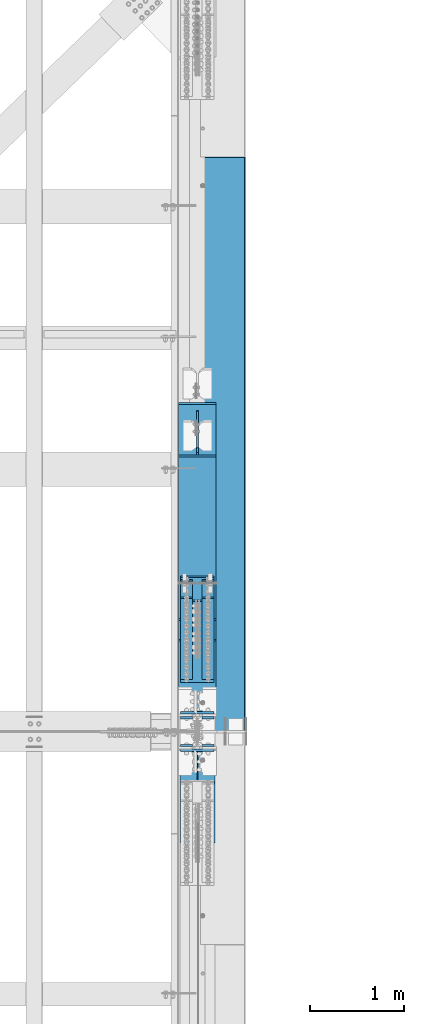
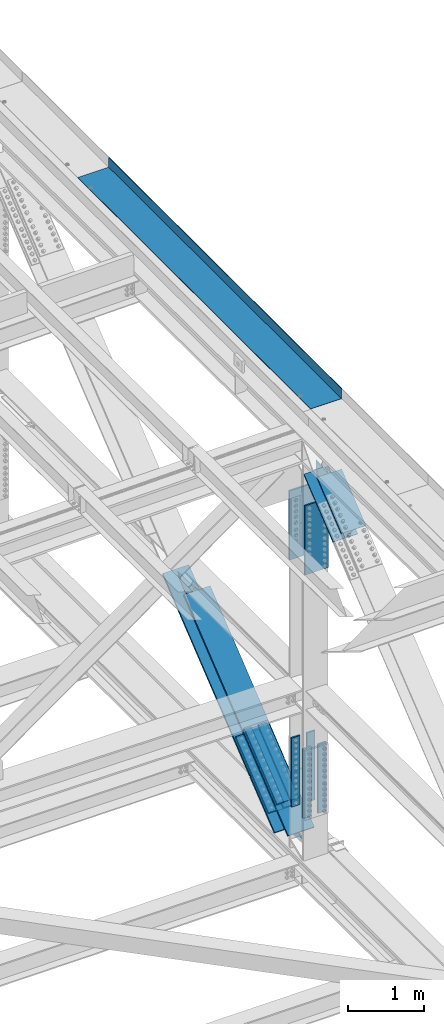
# One storey, part 1981 of 3843: 9 members, 7 beams, 4 elements without a shape of their own.
"""IFC2X3 building model written with IfcOpenShell, lengths in millimetres."""

from ifc_helpers import new_model, si_unit, frame, origin_with_axes, place, context, subcontext, project, spatial, faceted_brep, material, type_object, element, aggregate, save


model = new_model("IFC2X3")

# Units and contexts
model_context = context("Model", 3, precision=1e-05, world=origin_with_axes())
body_context = subcontext(model_context, "Body", "Model", "MODEL_VIEW")
ifc_project = project(units=[si_unit("LENGTHUNIT", "METRE", prefix="MILLI"), si_unit("AREAUNIT", "SQUARE_METRE"), si_unit("VOLUMEUNIT", "CUBIC_METRE"), si_unit("MASSUNIT", "GRAM", prefix="KILO"), si_unit("TIMEUNIT", "SECOND"), si_unit("PLANEANGLEUNIT", "RADIAN"), si_unit("SOLIDANGLEUNIT", "STERADIAN"), si_unit("THERMODYNAMICTEMPERATUREUNIT", "DEGREE_CELSIUS"), si_unit("LUMINOUSINTENSITYUNIT", "LUMEN")], contexts=[model_context])

# Site, building, storey
site_placement = place(None, origin_with_axes())
site = spatial("IfcSite", under=ifc_project, at=site_placement, CompositionType="ELEMENT")
building_placement = place(site_placement, origin_with_axes())
building = spatial("IfcBuilding", under=site, at=building_placement, Name="Undefined", CompositionType="ELEMENT")
storey_placement = place(building_placement, origin_with_axes())
storey = spatial("IfcBuildingStorey", under=building, at=storey_placement, Name="Undefined", CompositionType="ELEMENT", Elevation=0.0)

# Assembly, members
assembly_1_placement = place(storey_placement, origin_with_axes())
assembly_1 = element("IfcElementAssembly", 1, at=assembly_1_placement, inside=storey, Name="BEAM", AssemblyPlace="NOTDEFINED", PredefinedType="RIGID_FRAME")
ifc_material_1 = material(Name="STEEL/A572-50")
member_type_1 = type_object("IfcMemberType", PredefinedType="NOTDEFINED")
member_1_placement = place(assembly_1_placement, frame((85534.5, 77235.996749071, 40636.5082633789), z_axis=(1.0, 0.0, 0.0), x_axis=(0.0, -0.778233356622221, -0.62797519269515)))
member_1 = element("IfcMember", 2, at=member_1_placement, type_object=member_type_1, material=ifc_material_1, Name="PLATE", context=body_context, shape_type="Brep", body=[
    faceted_brep([(-4.36557456851006e-11, 12.7000000000116, -63.5), (-4.36557456851006e-11, 12.7000000000116, 63.5), (1104.90000001677, 12.7000000017251, 63.5), (1104.90000001677, 12.7000000017251, -63.5), (1.45519152283669e-11, -12.700000000008, 63.5), (1104.90000001682, -12.6999999982909, 63.5), (1.45519152283669e-11, -12.700000000008, -63.5), (1104.90000001682, -12.6999999982909, -63.5)], [[[0, 1, 2, 3]], [[1, 4, 5, 2]], [[4, 6, 7, 5]], [[6, 0, 3, 7]], [[5, 7, 3, 2]], [[6, 4, 1, 0]]]),
])
member_2_placement = place(assembly_1_placement, frame((85534.5, 77050.5713740765, 40866.3011174216), z_axis=(1.0, 0.0, 0.0), x_axis=(0.0, -0.778233356622221, -0.62797519269515)))
member_2 = element("IfcMember", 3, at=member_2_placement, type_object=member_type_1, material=ifc_material_1, Name="PLATE", context=body_context, shape_type="Brep", body=[
    faceted_brep([(-4.36557456851006e-11, 12.7000000000116, -63.5), (-4.36557456851006e-11, 12.7000000000116, 63.5), (1104.90000001677, 12.7000000017251, 63.5), (1104.90000001677, 12.7000000017251, -63.5), (1.45519152283669e-11, -12.700000000008, 63.5), (1104.90000001682, -12.6999999982909, 63.5), (1.45519152283669e-11, -12.700000000008, -63.5), (1104.90000001682, -12.6999999982909, -63.5)], [[[0, 1, 2, 3]], [[1, 4, 5, 2]], [[4, 6, 7, 5]], [[6, 0, 3, 7]], [[5, 7, 3, 2]], [[6, 4, 1, 0]]]),
])
member_3_placement = place(assembly_1_placement, frame((85763.1, 77235.9967490711, 40636.5082633788), z_axis=(1.0, 0.0, 0.0), x_axis=(0.0, -0.778233356622221, -0.62797519269515)))
member_3 = element("IfcMember", 4, at=member_3_placement, type_object=member_type_1, material=ifc_material_1, Name="PLATE", context=body_context, shape_type="Brep", body=[
    faceted_brep([(-4.36557456851006e-11, 12.7000000000116, -63.5), (-4.36557456851006e-11, 12.7000000000116, 63.5), (1104.90000001677, 12.7000000017251, 63.5), (1104.90000001677, 12.7000000017251, -63.5), (1.45519152283669e-11, -12.700000000008, 63.5), (1104.90000001682, -12.6999999982909, 63.5), (1.45519152283669e-11, -12.700000000008, -63.5), (1104.90000001682, -12.6999999982909, -63.5)], [[[0, 1, 2, 3]], [[1, 4, 5, 2]], [[4, 6, 7, 5]], [[6, 0, 3, 7]], [[5, 7, 3, 2]], [[6, 4, 1, 0]]]),
])
member_4_placement = place(assembly_1_placement, frame((85763.1, 77050.5713745982, 40866.3011167751), z_axis=(1.0, 0.0, 0.0), x_axis=(0.0, -0.778233356622221, -0.62797519269515)))
member_4 = element("IfcMember", 5, at=member_4_placement, type_object=member_type_1, material=ifc_material_1, Name="PLATE", context=body_context, shape_type="Brep", body=[
    faceted_brep([(-4.36557456851006e-11, 12.7000000000116, -63.5), (-4.36557456851006e-11, 12.7000000000116, 63.5), (1104.90000001677, 12.7000000017251, 63.5), (1104.90000001677, 12.7000000017251, -63.5), (1.45519152283669e-11, -12.700000000008, 63.5), (1104.90000001682, -12.6999999982909, 63.5), (1.45519152283669e-11, -12.700000000008, -63.5), (1104.90000001682, -12.6999999982909, -63.5)], [[[0, 1, 2, 3]], [[1, 4, 5, 2]], [[4, 6, 7, 5]], [[6, 0, 3, 7]], [[5, 7, 3, 2]], [[6, 4, 1, 0]]]),
])
member_type_2 = type_object("IfcMemberType", PredefinedType="NOTDEFINED")
member_5_placement = place(assembly_1_placement, frame((85648.8, 76411.0185856349, 39899.4178813718), z_axis=(1.0, 0.0, 0.0), x_axis=(0.0, 0.778233356622216, 0.627975192695157)))
member_5 = element("IfcMember", 6, at=member_5_placement, type_object=member_type_2, material=ifc_material_1, Name="PLATE", context=body_context, shape_type="Brep", body=[
    faceted_brep([(-1.45519152283669e-11, 12.7000000000025, -177.800000000003), (-1.45519152283669e-11, 12.7000000000025, 177.800000000003), (1104.90000001682, 12.7000000017051, 177.800000000003), (1104.90000001682, 12.7000000017051, -177.800000000003), (4.36557456851006e-11, -12.7000000000171, 177.800000000003), (1104.90000001686, -12.6999999983072, 177.800000000003), (4.36557456851006e-11, -12.7000000000171, -177.800000000003), (1104.90000001686, -12.6999999983072, -177.800000000003)], [[[0, 1, 2, 3]], [[1, 4, 5, 2]], [[4, 6, 7, 5]], [[6, 0, 3, 7]], [[5, 7, 3, 2]], [[6, 4, 1, 0]]]),
])
member_6_placement = place(assembly_1_placement, frame((85648.8, 76155.8094669572, 40215.6919175462), z_axis=(1.0, 0.0, 0.0), x_axis=(0.0, 0.778233356622216, 0.627975192695157)))
member_6 = element("IfcMember", 7, at=member_6_placement, type_object=member_type_2, material=ifc_material_1, Name="PLATE", context=body_context, shape_type="Brep", body=[
    faceted_brep([(-1.45519152283669e-11, 12.7000000000025, -177.800000000003), (-1.45519152283669e-11, 12.7000000000025, 177.800000000003), (1104.90000001682, 12.7000000017051, 177.800000000003), (1104.90000001682, 12.7000000017051, -177.800000000003), (4.36557456851006e-11, -12.7000000000171, 177.800000000003), (1104.90000001686, -12.6999999983072, 177.800000000003), (4.36557456851006e-11, -12.7000000000171, -177.800000000003), (1104.90000001686, -12.6999999983072, -177.800000000003)], [[[0, 1, 2, 3]], [[1, 4, 5, 2]], [[4, 6, 7, 5]], [[6, 0, 3, 7]], [[5, 7, 3, 2]], [[6, 4, 1, 0]]]),
])

# Assembly, member
assembly_2_placement = place(storey_placement, origin_with_axes())
assembly_2 = element("IfcElementAssembly", 8, at=assembly_2_placement, inside=storey, Name="BEAM", AssemblyPlace="NOTDEFINED", PredefinedType="RIGID_FRAME")
ifc_material_2 = material(Name="STEEL/A992")
member_type_3 = type_object("IfcMemberType", Name="W14X99", PredefinedType="NOTDEFINED")
member_7_placement = place(assembly_2_placement, frame((85648.8, 74556.0890731402, 45434.5200894619), z_axis=(0.0, -0.628634438193607, 0.777700934239511), x_axis=(0.0, 0.777700934239509, 0.628634438193609)))
member_7 = element("IfcMember", 9, at=member_7_placement, type_object=member_type_3, material=ifc_material_2, Name="BEAM", ObjectType="W14X99", context=body_context, shape_type="Brep", body=[
    faceted_brep([(863.036991471847, 6.35000000000582, 131.548571949694), (883.164308317369, -6.35000000000582, 131.535296008129), (1099.85576210526, -6.35000000000582, -44.9452300874618), (1082.0284716633, 6.35000000000582, -46.8051700140422), (799.409599719962, 6.35000000000582, 131.590540461475), (799.409599719962, -6.35000000000582, 131.590540461475), (794.370695951802, 6.35000000000582, 133.036446999322), (794.370695951802, -6.35000000000582, 133.036446999322), (790.86000180518, 6.35000000000582, 136.929546472711), (790.86000180518, -6.35000000000582, 136.929546472711), (789.940922297508, 6.35000000000582, 142.090601574069), (789.940922297508, -6.35000000000582, 142.090601574069), (791.891850737593, 6.35000000000582, 146.956305543928), (791.891850737593, -6.35000000000582, 146.956305543928), (803.767820519191, 6.35000000000582, 160.337500002468), (824.515053178344, 6.35000000000582, 160.337500002555), (824.515025145622, 6.35000000000582, 160.276325287436), (803.767820519191, 185.737500000003, 160.337500002468), (824.515053178344, 185.737500000003, 160.337500002555), (6.35000000639411, 6.35000000000582, 160.337500001014), (6.35000000639411, 185.737500000003, 160.337500001014), (802.27942614755, 185.737500000003, 160.337500002461), (802.27942614755, 6.35000000000582, 160.337500002461), (803.767820519191, -6.35000000000582, 160.337500002468), (824.515025145622, -6.35000000000582, 160.276325287436), (824.515053178344, -6.35000000000582, 160.337500002555), (803.767820519191, -185.737500000003, 160.337500002468), (824.515053178344, -185.737500000003, 160.337500002555), (6.35000000636501, -185.737500000003, 179.387500001133), (6.35000000639411, -185.737500000003, 160.337500001014), (802.27942614755, -185.737500000003, 160.337500002461), (802.282825191447, -185.737500000003, 160.341878624597), (824.523782658434, -185.737500000003, 179.387500002449), (6.35000000636501, 185.737500000003, 179.387500001133), (824.523782658434, 185.737500000003, 179.387500002449), (802.282825191447, 185.737500000003, 160.341878624597), (802.27942614755, -6.35000000000582, 160.337500002461), (6.35000000639411, -6.35000000000582, 160.337500001014), (6.35000000674336, -6.35000000000582, -160.33750000099), (970.01614896825, -6.35000000000582, -160.337499995272), (959.845678550802, -6.35000000000582, -147.190690371135), (957.903240569896, -6.35000000000582, -142.325266410233), (958.827454152473, -6.35000000000582, -137.168596469011), (962.33873535585, -6.35000000000582, -133.28062528342), (967.374886154561, -6.35000000000582, -131.837503402887), (1029.6986799489, -6.35000000000582, -131.807587091236), (959.845678550802, 6.35000000000582, -147.190690371135), (957.903240569896, 6.35000000000582, -142.325266410233), (958.827454152473, 6.35000000000582, -137.168596469011), (962.33873535585, 6.35000000000582, -133.28062528342), (967.374886154561, 6.35000000000582, -131.837503402887), (1013.36729613983, 6.35000000000582, -131.815426388843), (970.01614896825, 6.35000000000582, -160.337499995272), (6.35000000674336, 6.35000000000582, -160.33750000099), (6.35000000674336, 185.737500000003, -160.33750000099), (970.01614896825, 185.737500000003, -160.337499995272), (6.35000000674336, -185.737500000003, -179.387500001117), (6.35000000674336, -185.737500000003, -160.33750000099), (6.35000000674336, 185.737500000003, -179.387500001117), (970.01614896825, -185.737500000003, -160.337499995272), (970.031073522201, -185.737500000003, -160.356792147955), (970.031073522201, 185.737500000003, -160.356792147955), (981.380989115074, 185.737500000003, -160.337499995228), (981.380989115074, 6.35000000000582, -160.337499995228), (991.044260056995, 6.35000000000582, -160.337499995192), (991.044260056995, 185.737500000003, -160.337499995192), (991.03553058875, 185.737500000003, -179.387499995093), (991.03553058875, -185.737500000003, -179.387499995093), (981.380989115074, -185.737500000003, -160.337499995228), (991.044260056995, -185.737500000003, -160.337499995192), (981.380989115074, -6.35000000000582, -160.337499995228), (991.044267583711, -6.35000000000582, -160.321074723841), (991.044267583711, 6.35000000000582, -160.321074723841)], [[[0, 1, 2, 3]], [[4, 5, 1, 0]], [[5, 4, 6, 7]], [[7, 6, 8, 9]], [[9, 8, 10, 11]], [[11, 10, 12, 13]], [[14, 15, 16]], [[14, 17, 18, 15]], [[19, 20, 21, 22]], [[23, 24, 25]], [[26, 23, 25, 27]], [[28, 29, 30, 31, 26, 27, 32]], [[33, 28, 32, 34]], [[17, 35, 21, 20, 33, 34, 18]], [[32, 27, 25, 24, 16, 15, 18, 34]], [[23, 26, 31, 35, 17, 14, 16, 24]], [[30, 36, 13, 12, 22, 21, 35, 31]], [[29, 37, 36, 30]], [[1, 5, 7, 9, 11, 13, 36, 37, 38, 39, 40, 41, 42, 43, 44, 45, 2]], [[40, 46, 47, 41]], [[41, 47, 48, 42]], [[42, 48, 49, 43]], [[43, 49, 50, 44]], [[44, 50, 51, 45]], [[2, 45, 51, 3]], [[50, 49, 48, 47, 46, 52, 53, 19, 22, 12, 10, 8, 6, 4, 0, 3, 51]], [[54, 53, 52, 55]], [[56, 57, 38, 37, 29, 28, 33, 20, 19, 53, 54, 58]], [[38, 57, 59, 39]], [[60, 61, 55, 52, 46, 40, 39, 59]], [[62, 63, 64, 65]], [[58, 54, 55, 61, 62, 65, 66]], [[56, 58, 66, 67]], [[68, 60, 59, 57, 56, 67, 69]], [[70, 68, 69, 71]], [[72, 63, 62, 61, 60, 68, 70, 71]], [[69, 67, 66, 65, 64, 72, 71]], [[63, 72, 64]]]),
])

# Beam
beam_type_1 = type_object("IfcBeamType", PredefinedType="NOTDEFINED")
beam_1_placement = place(assembly_1_placement, frame((85763.1, 75480.8625000002, 41508.7839713305), z_axis=(-1.0, 0.0, 0.0), x_axis=(0.0, 0.0, -1.0)))
beam_1 = element("IfcBeam", 10, at=beam_1_placement, type_object=beam_type_1, material=ifc_material_1, Name="PLATE", context=body_context, shape_type="Brep", body=[
    faceted_brep([(-4.36557456851006e-11, 12.7000000000116, -63.5), (-4.36557456851006e-11, 12.7000000000116, 63.5), (1104.90000001677, 12.7000000017251, 63.5), (1104.90000001677, 12.7000000017251, -63.5), (1.45519152283669e-11, -12.700000000008, 63.5), (1104.90000001682, -12.6999999982909, 63.5), (1.45519152283669e-11, -12.700000000008, -63.5), (1104.90000001682, -12.6999999982909, -63.5)], [[[0, 1, 2, 3]], [[1, 4, 5, 2]], [[4, 6, 7, 5]], [[6, 0, 3, 7]], [[5, 7, 3, 2]], [[6, 4, 1, 0]]]),
])

beam_2_placement = place(assembly_1_placement, frame((85763.1, 75776.1375000002, 41508.7839713305), z_axis=(-1.0, 0.0, 0.0), x_axis=(0.0, 0.0, -1.0)))
beam_2 = element("IfcBeam", 11, at=beam_2_placement, type_object=beam_type_1, material=ifc_material_1, Name="PLATE", context=body_context, shape_type="Brep", body=[
    faceted_brep([(-4.36557456851006e-11, 12.7000000000116, -63.5), (-4.36557456851006e-11, 12.7000000000116, 63.5), (1104.90000001677, 12.7000000017251, 63.5), (1104.90000001677, 12.7000000017251, -63.5), (1.45519152283669e-11, -12.700000000008, 63.5), (1104.90000001682, -12.6999999982909, 63.5), (1.45519152283669e-11, -12.700000000008, -63.5), (1104.90000001682, -12.6999999982909, -63.5)], [[[0, 1, 2, 3]], [[1, 4, 5, 2]], [[4, 6, 7, 5]], [[6, 0, 3, 7]], [[5, 7, 3, 2]], [[6, 4, 1, 0]]]),
])

beam_3_placement = place(assembly_1_placement, frame((85534.5, 75480.8625000002, 41508.7839713305), z_axis=(-1.0, 0.0, 0.0), x_axis=(0.0, 0.0, -1.0)))
beam_3 = element("IfcBeam", 12, at=beam_3_placement, type_object=beam_type_1, material=ifc_material_1, Name="PLATE", context=body_context, shape_type="Brep", body=[
    faceted_brep([(-4.36557456851006e-11, 12.7000000000116, -63.5), (-4.36557456851006e-11, 12.7000000000116, 63.5), (1104.90000001677, 12.7000000017251, 63.5), (1104.90000001677, 12.7000000017251, -63.5), (1.45519152283669e-11, -12.700000000008, 63.5), (1104.90000001682, -12.6999999982909, 63.5), (1.45519152283669e-11, -12.700000000008, -63.5), (1104.90000001682, -12.6999999982909, -63.5)], [[[0, 1, 2, 3]], [[1, 4, 5, 2]], [[4, 6, 7, 5]], [[6, 0, 3, 7]], [[5, 7, 3, 2]], [[6, 4, 1, 0]]]),
])

beam_4_placement = place(assembly_1_placement, frame((85534.5, 75776.1375000002, 41508.7839713305), z_axis=(-1.0, 0.0, 0.0), x_axis=(0.0, 0.0, -1.0)))
beam_4 = element("IfcBeam", 13, at=beam_4_placement, type_object=beam_type_1, material=ifc_material_1, Name="PLATE", context=body_context, shape_type="Brep", body=[
    faceted_brep([(-4.36557456851006e-11, 12.7000000000116, -63.5), (-4.36557456851006e-11, 12.7000000000116, 63.5), (1104.90000001677, 12.7000000017251, 63.5), (1104.90000001677, 12.7000000017251, -63.5), (1.45519152283669e-11, -12.700000000008, 63.5), (1104.90000001682, -12.6999999982909, 63.5), (1.45519152283669e-11, -12.700000000008, -63.5), (1104.90000001682, -12.6999999982909, -63.5)], [[[0, 1, 2, 3]], [[1, 4, 5, 2]], [[4, 6, 7, 5]], [[6, 0, 3, 7]], [[5, 7, 3, 2]], [[6, 4, 1, 0]]]),
])

beam_type_2 = type_object("IfcBeamType", PredefinedType="NOTDEFINED")
beam_5_placement = place(assembly_2_placement, frame((85648.8, 75430.0624174976, 45426.7444725712), z_axis=(1.0, 0.0, 0.0), x_axis=(0.0, 0.0, -1.0)))
beam_5 = element("IfcBeam", 14, at=beam_5_placement, type_object=beam_type_2, material=ifc_material_1, Name="PLATE", context=body_context, shape_type="Brep", body=[
    faceted_brep([(-1.45519152283669e-11, 12.7000000000025, -177.800000000003), (-1.45519152283669e-11, 12.7000000000025, 177.800000000003), (1104.90000001682, 12.7000000017051, 177.800000000003), (1104.90000001682, 12.7000000017051, -177.800000000003), (4.36557456851006e-11, -12.7000000000171, 177.800000000003), (1104.90000001686, -12.6999999983072, 177.800000000003), (4.36557456851006e-11, -12.7000000000171, -177.800000000003), (1104.90000001686, -12.6999999983072, -177.800000000003)], [[[0, 1, 2, 3]], [[1, 4, 5, 2]], [[4, 6, 7, 5]], [[6, 0, 3, 7]], [[5, 7, 3, 2]], [[6, 4, 1, 0]]]),
])

beam_6_placement = place(assembly_2_placement, frame((85648.8, 75826.9379506759, 45426.7444324848), z_axis=(1.0, 0.0, 0.0), x_axis=(0.0, 0.0, -1.0)))
beam_6 = element("IfcBeam", 15, at=beam_6_placement, type_object=beam_type_2, material=ifc_material_1, Name="PLATE", context=body_context, shape_type="Brep", body=[
    faceted_brep([(-1.45519152283669e-11, 12.7000000000025, -177.800000000003), (-1.45519152283669e-11, 12.7000000000025, 177.800000000003), (1104.90000001682, 12.7000000017051, 177.800000000003), (1104.90000001682, 12.7000000017051, -177.800000000003), (4.36557456851006e-11, -12.7000000000171, 177.800000000003), (1104.90000001686, -12.6999999983072, 177.800000000003), (4.36557456851006e-11, -12.7000000000171, -177.800000000003), (1104.90000001686, -12.6999999983072, -177.800000000003)], [[[0, 1, 2, 3]], [[1, 4, 5, 2]], [[4, 6, 7, 5]], [[6, 0, 3, 7]], [[5, 7, 3, 2]], [[6, 4, 1, 0]]]),
])

aggregate(assembly_2, [member_7, beam_5, beam_6])

# Assembly, member
assembly_3_placement = place(storey_placement, origin_with_axes())
assembly_3 = element("IfcElementAssembly", 16, at=assembly_3_placement, inside=storey, Name="V. BRACE", AssemblyPlace="NOTDEFINED", PredefinedType="RIGID_FRAME")
member_type_4 = type_object("IfcMemberType", Name="W14X159", PredefinedType="NOTDEFINED")
member_8_placement = place(assembly_3_placement, frame((85648.8, 76713.3490440191, 40404.4797948248), z_axis=(0.0, -0.627975192695145, 0.778233356622225), x_axis=(0.0, 0.778233356622216, 0.627975192695157)))
member_8 = element("IfcMember", 17, at=member_8_placement, type_object=member_type_4, material=ifc_material_2, Name="V. BRACE", ObjectType="W14X159", context=body_context, shape_type="Brep", body=[
    faceted_brep([(2544.37877223172, -9.52499999999418, 160.020456943068), (2456.46503316336, -9.52500000003783, 159.959075778439), (2456.46503316336, 9.52499999999418, 159.959075778439), (2544.37877222575, 9.52499999999418, 160.020456943053), (2456.48533936829, -9.52500000003783, 130.875333070981), (2456.48533936829, 9.52499999999418, 130.875333070981), (2457.21853603238, -9.52500000003783, 127.217306150425), (2457.21853603238, 9.52499999999418, 127.217306150425), (2459.30053334672, -9.52500000003783, 124.121498423388), (2459.30053334672, 9.52499999999418, 124.121498423388), (2462.4119201407, -9.52500000003783, 122.062855540884), (2462.4119201407, 9.52499999999418, 122.062855540884), (2466.0753606892, -9.52500000003783, 121.357205735887), (2466.0753606892, 9.52499999999418, 121.357205735887), (2590.96966589964, 9.52499999999418, 122.209837743936), (2560.99076219696, -9.52499999999418, 122.005176908362), (6.34999999483989, -198.4375, -190.499999999538), (6.34999999483989, 198.4375, -190.499999999538), (2939.10417762486, 198.4375, -190.499999980326), (2939.10417762486, -198.4375, -190.499999980326), (2544.26881450854, -9.52499999999418, 160.109692612776), (2544.26881450618, 9.52499999999418, 160.109692609843), (2507.26502079051, 9.52499999999418, 159.994544211684), (2507.26502079051, -9.52499999999418, 159.994544211684), (6.34999999323918, 198.4375, 160.337499999503), (6.34999999309366, 198.4375, 190.499999999422), (2506.82135632803, 198.4375, 190.500000017561), (2507.24396140865, 198.4375, 190.157036865003), (2507.2647813395, 198.4375, 160.337500017496), (2506.82135632803, -198.4375, 190.500000017561), (2507.24396140865, -198.4375, 190.157036865003), (6.34999999309366, -198.4375, 190.499999999422), (6.34999999323918, -198.4375, 160.337499999503), (2507.2647813395, -198.4375, 160.337500017496), (6.34999999323918, -9.52499999999418, 160.337499999503), (2507.2647813395, -9.52499999999418, 160.337500017496), (2507.2647813395, 9.52499999999418, 160.337500017496), (6.34999999323918, 9.52499999999418, 160.337499999503), (6.34999999470892, -198.4375, -160.337499999619), (6.34999999470892, -9.52499999999418, -160.337499999619), (6.34999999470892, 9.52499999999418, -160.337499999619), (6.34999999470892, 198.4375, -160.337499999619), (2853.96783822778, 9.52499999999418, -160.33749998084), (2853.96783822778, 198.4375, -160.33749998084), (2919.86552045299, 9.52499999999418, -160.337499980389), (2939.08309765431, 9.52499999999418, -160.30802474709), (2939.08311823386, 9.52499999999418, -160.337499980258), (2919.86552045299, 198.4375, -160.337499980389), (2939.08311823386, 198.4375, -160.337499980258), (2854.09303431977, 198.4375, -160.438379469706), (2919.86552045299, -9.52499999999418, -160.337499980389), (2939.08311823386, -9.52499999999418, -160.337499980258), (2939.08309765431, -9.52500000000873, -160.30802474709), (2854.09303431977, -198.4375, -160.438379469706), (2919.86552045299, -198.4375, -160.337499980389), (2939.08311823386, -198.4375, -160.337499980258), (2853.96783822778, -198.4375, -160.33749998084), (2853.96783822778, -9.52499999999418, -160.33749998084), (2828.10661848611, 9.52499999999418, -139.499256754458), (2828.10661848611, -9.52500000009604, -139.499256754458), (2824.9228103436, 9.52499999999418, -134.693594239339), (2824.9228103436, -9.52500000009604, -134.693594239339), (2825.09416644015, 9.52499999999418, -128.931505764955), (2825.09416644015, -9.52500000009604, -128.931505764955), (2828.5579223755, 9.52499999999418, -124.323532097642), (2828.5579223755, -9.52500000009604, -124.323532097642), (2834.04537182231, 9.52499999999418, -122.557484231307), (2834.04537182231, -9.52500000009604, -122.557484231307), (2892.29333184467, 9.52499999999418, -122.327956883481), (2862.20832163215, -9.52499999999418, -122.446507517376)], [[[0, 1, 2, 3]], [[4, 5, 2, 1]], [[6, 7, 5, 4]], [[8, 9, 7, 6]], [[10, 11, 9, 8]], [[12, 13, 11, 10]], [[14, 13, 12, 15]], [[16, 17, 18, 19]], [[20, 21, 22, 23]], [[24, 25, 26, 27, 28]], [[26, 29, 30, 27]], [[25, 31, 29, 26]], [[29, 31, 32, 33, 30]], [[32, 34, 35, 33]], [[23, 22, 36, 28, 27, 30, 33, 35]], [[37, 24, 28, 36]], [[16, 38, 39, 34, 32, 31, 25, 24, 37, 40, 41, 17]], [[41, 40, 42, 43]], [[44, 45, 46]], [[47, 44, 46, 48]], [[17, 41, 43, 49, 47, 48, 18]], [[50, 51, 52]], [[44, 47, 49, 53, 54, 50, 52, 45]], [[50, 54, 55, 51]], [[19, 18, 48, 46, 45, 52, 51, 55]], [[54, 53, 56, 38, 16, 19, 55]], [[39, 38, 56, 57]], [[53, 49, 43, 42, 58, 59, 57, 56]], [[59, 58, 60, 61]], [[61, 60, 62, 63]], [[63, 62, 64, 65]], [[65, 64, 66, 67]], [[68, 69, 67, 66]], [[69, 68, 14, 15]], [[10, 8, 6, 4, 1, 0, 20, 23, 35, 34, 39, 57, 59, 61, 63, 65, 67, 69, 15, 12]], [[21, 20, 0, 3]], [[68, 66, 64, 62, 60, 58, 42, 40, 37, 36, 22, 21, 3, 2, 5, 7, 9, 11, 13, 14]]]),
])
aggregate(assembly_3, [member_8])

# Member
member_9_placement = place(assembly_1_placement, frame((85648.8, 75628.6018372347, 39529.1712115785), z_axis=(0.0, -0.627975192695145, 0.778233356622225), x_axis=(0.0, 0.778233356622216, 0.627975192695157)))
member_9 = element("IfcMember", 18, at=member_9_placement, type_object=member_type_4, material=ifc_material_2, Name="BEAM", ObjectType="W14X159", context=body_context, shape_type="Brep", body=[
    faceted_brep([(591.062861731087, -9.52499999999418, -160.048210234825), (591.062861731087, 9.52499999999418, -160.048210234825), (568.837864403104, 9.52499999999418, -160.059093040891), (568.837864403104, -9.52499999999418, -160.059093040891), (608.544679591636, -9.52499999999418, -137.267055120436), (608.544679591636, 9.52499999999418, -137.267055120436), (610.4674099166, -9.52499999999418, -132.401040727822), (610.4674099166, 9.52499999999418, -132.401040727822), (609.529937480969, -9.52499999999418, -127.253601228036), (609.529937480969, 9.52499999999418, -127.253601228036), (606.015129431777, -9.52499999999418, -123.377893247747), (606.015129431777, 9.52499999999418, -123.377893247747), (600.983522257768, -9.52499999999418, -121.943348993562), (600.983522257768, 9.52499999999418, -121.943348993562), (484.924340407568, -9.52499999999418, -122.000171982945), (515.107848238942, 9.52499999915017, -121.985394029856), (279.217776534148, -9.52500000009604, 45.2098340554003), (305.956055661751, 9.52499999915017, 48.0250900365681), (1387.50853605266, -198.4375, 190.500000009892), (1387.50853605266, 198.4375, 190.500000009892), (397.428596378886, 198.4375, 190.500000003129), (397.428596378886, -198.4375, 190.500000003129), (418.734719141692, -198.4375, 160.542465041675), (418.892010791897, -198.4375, 160.337500003207), (1387.50853605251, -198.4375, 160.337500009824), (396.509721792332, -198.4375, 160.531584879016), (418.734719141692, 198.4375, 160.542465041675), (396.509721792332, 198.4375, 160.531584879016), (1387.50853605251, 198.4375, 160.337500009824), (418.892010791897, 198.4375, 160.337500003207), (1387.50853605251, 9.52499999999418, 160.337500009824), (418.892010791897, 9.52499999999418, 160.337500003207), (365.924250808632, 9.52499999591964, 122.416607280229), (428.657855591126, 9.52499999999418, 122.447318314407), (433.686110312643, 9.52499999999418, 123.885577175235), (437.197042414438, 9.52499999999418, 127.76182405488), (438.132177059291, 9.52499999999418, 132.90744911812), (436.209590113576, 9.52499999999418, 137.771150746663), (1387.50853605104, 9.52499999999418, -160.337499990877), (568.83800069672, 9.52499999999418, -160.337499996473), (1387.50853605104, 198.4375, -160.337499990877), (568.83800069672, 198.4375, -160.337499996473), (1387.50853605091, 198.4375, -190.499999990952), (567.7989214439, 198.4375, -190.499999996555), (568.852630395704, 198.4375, -190.221586834861), (1387.50853605251, -9.52499999999418, 160.337500009824), (1387.50853605104, -9.52499999999418, -160.337499990877), (1387.50853605104, -198.4375, -160.337499990877), (1387.50853605091, -198.4375, -190.499999990952), (568.83800069672, -9.52499999999418, -160.337499996473), (568.83800069672, -198.4375, -160.337499996473), (568.852630395704, -198.4375, -190.221586834861), (567.7989214439, -198.4375, -190.499999996555), (418.892010791897, -9.52499999999418, 160.337500003207), (436.209590113576, -9.52499999999418, 137.771150746663), (438.132177059291, -9.52499999999418, 132.90744911812), (437.197042414438, -9.52499999999418, 127.76182405488), (433.686110312643, -9.52499999999418, 123.885577175235), (428.657855591126, -9.52499999999418, 122.447318314407), (341.445734684938, -9.52499999999418, 122.404623901504)], [[[0, 1, 2, 3]], [[4, 5, 1, 0]], [[6, 7, 5, 4]], [[8, 9, 7, 6]], [[10, 11, 9, 8]], [[12, 13, 11, 10]], [[13, 12, 14, 15]], [[15, 14, 16, 17]], [[18, 19, 20, 21]], [[22, 23, 24, 18, 21, 25]], [[26, 22, 25, 27]], [[21, 20, 27, 25]], [[19, 28, 29, 26, 27, 20]], [[28, 30, 31, 29]], [[1, 5, 7, 9, 11, 13, 15, 17, 32, 33, 34, 35, 36, 37, 31, 30, 38, 39, 2]], [[38, 40, 41, 39]], [[40, 42, 43, 44, 41]], [[38, 30, 28, 19, 18, 24, 45, 46, 47, 48, 42, 40]], [[47, 46, 49, 50]], [[48, 47, 50, 51, 52]], [[42, 48, 52, 43]], [[51, 44, 43, 52]], [[50, 49, 3, 2, 39, 41, 44, 51]], [[46, 45, 53, 54, 55, 56, 57, 58, 59, 16, 14, 12, 10, 8, 6, 4, 0, 3, 49]], [[32, 17, 16, 59]], [[58, 33, 32, 59]], [[57, 34, 33, 58]], [[56, 35, 34, 57]], [[55, 36, 35, 56]], [[54, 37, 36, 55]], [[53, 23, 22, 26, 29, 31, 37, 54]], [[45, 24, 23, 53]]]),
])

aggregate(assembly_1, [member_1, member_2, member_3, member_4, member_5, member_6, member_9, beam_1, beam_2, beam_3, beam_4])

# Assembly, beam
assembly_4_placement = place(storey_placement, origin_with_axes())
assembly_4 = element("IfcElementAssembly", 19, at=assembly_4_placement, inside=storey, Name="BEAM", AssemblyPlace="NOTDEFINED", PredefinedType="RIGID_FRAME")
ifc_material_3 = material(Name="STEEL/A36")
beam_type_3 = type_object("IfcBeamType", PredefinedType="NOTDEFINED")
beam_7_placement = place(assembly_4_placement, frame((85680.5500000025, 78676.5, 46772.5125), z_axis=(0.0, -1.0, 0.0), x_axis=(1.0, 0.0, 0.0)))
beam_7 = element("IfcBeam", 20, at=beam_7_placement, type_object=beam_type_3, material=ifc_material_3, Name="BENT_PLATE", context=body_context, shape_type="Brep", body=[
    faceted_brep([(466.724998474107, 4.76249999999709, -3044.82500004767), (469.899999921181, 1.58750004768081, -3048.0), (0.0, 1.58750004768081, -3048.0), (0.0, 4.76249999999709, -3044.82500004768), (466.725000000006, 160.337499999994, -3044.82500004767), (469.900001478221, 160.337499968853, -3048.0), (0.0, 4.76249999999709, 3048.0), (466.724998474107, 4.76249999999709, 3048.0), (0.0, -4.76249999999709, -3048.0), (0.0, -4.76249999999709, 3048.0), (476.249998380677, -4.76249999999709, -3048.0), (476.249998380677, -4.76249999999709, 3048.0), (466.725000000006, 160.337499999994, 3048.0), (476.25, 160.337499906571, 3048.0), (476.25, 160.337499906571, -3048.0)], [[[0, 1, 2, 3]], [[4, 5, 1, 0]], [[6, 7, 0, 3]], [[8, 9, 6, 3, 2]], [[9, 8, 10, 11]], [[7, 12, 4, 0]], [[7, 6, 9, 11, 13, 12]], [[11, 10, 14, 13]], [[5, 14, 10, 8, 2, 1]], [[12, 13, 14, 5, 4]]]),
])
aggregate(assembly_4, [beam_7])

save(model, "model.ifc")
